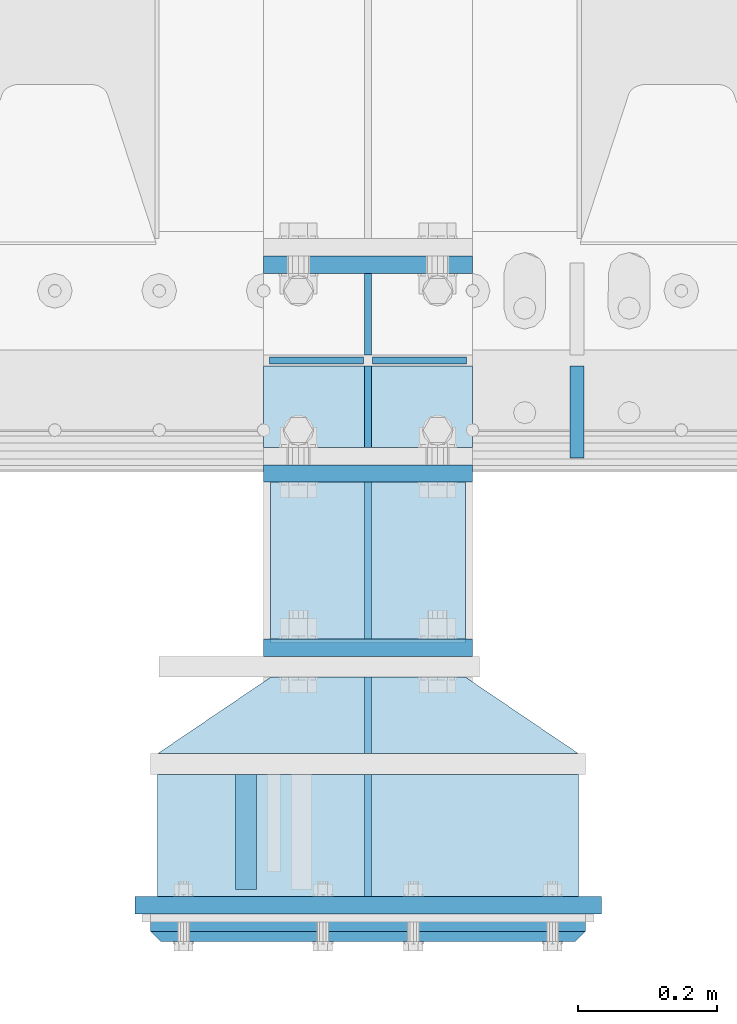
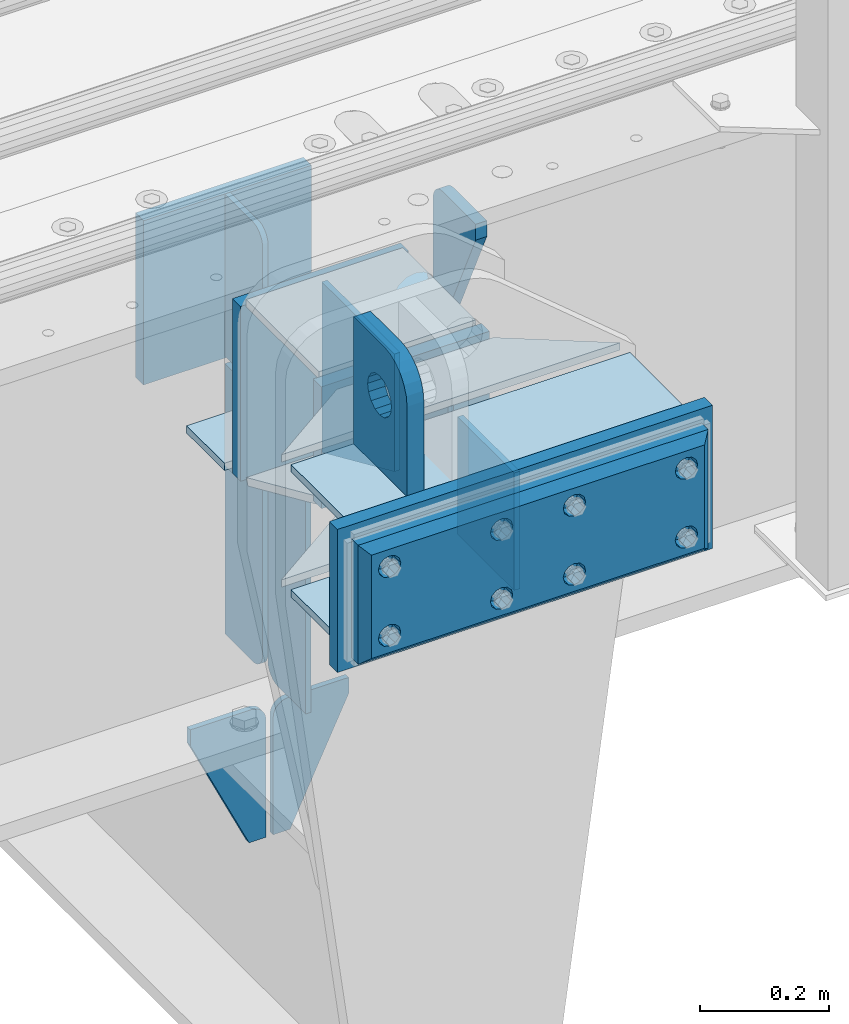
# One storey, part 205 of 247: 22 plates.
"""IFC2X3 building model written with IfcOpenShell, lengths in millimetres."""

from ifc_helpers import new_model, si_unit, frame, origin_with_axes, place, context, subcontext, project, spatial, faceted_brep, material, type_object, element, save


model = new_model("IFC2X3")

# Units and contexts
model_context = context("Model", 3, precision=1e-05, world=origin_with_axes())
body_context = subcontext(model_context, "Body", "Model", "MODEL_VIEW")
ifc_project = project(units=[si_unit("LENGTHUNIT", "METRE", prefix="MILLI"), si_unit("AREAUNIT", "SQUARE_METRE"), si_unit("VOLUMEUNIT", "CUBIC_METRE"), si_unit("MASSUNIT", "GRAM", prefix="KILO"), si_unit("TIMEUNIT", "SECOND"), si_unit("PLANEANGLEUNIT", "RADIAN"), si_unit("SOLIDANGLEUNIT", "STERADIAN"), si_unit("THERMODYNAMICTEMPERATUREUNIT", "DEGREE_CELSIUS"), si_unit("LUMINOUSINTENSITYUNIT", "LUMEN")], contexts=[model_context])

# Site, building, storey
site_placement = place(None, origin_with_axes())
site = spatial("IfcSite", under=ifc_project, at=site_placement, CompositionType="ELEMENT")
building_placement = place(site_placement, origin_with_axes())
building = spatial("IfcBuilding", under=site, at=building_placement, Name="Standard", CompositionType="ELEMENT")
storey_placement = place(building_placement, origin_with_axes())
storey = spatial("IfcBuildingStorey", under=building, at=storey_placement, Name="Undefined", CompositionType="ELEMENT", Elevation=0.0)

# Plates
ifc_material_1 = material(Name="STEEL/S355N")
plate_type_1 = type_object("IfcPlateType", PredefinedType="NOTDEFINED")
plate_1_placement = place(storey_placement, frame((12100.0000000129, -162.500000015315, -340.000018222573), z_axis=(0.0, 0.0, 1.0), x_axis=(1.0, 0.0, 0.0)))
element("IfcPlate", 1, at=plate_1_placement, inside=storey, type_object=plate_type_1, material=ifc_material_1, context=body_context, shape_type="Brep", body=[
    faceted_brep([(0.0, -12.5, 0.0), (0.0, -12.5, 330.0), (0.0, 12.5, 330.0), (0.0, 12.5, 0.0), (300.0, -12.5, 330.0), (300.0, 12.5, 330.0), (300.0, -12.5, 0.0), (300.0, 12.5, 0.0)], [[[0, 1, 2, 3]], [[1, 4, 5, 2]], [[4, 6, 7, 5]], [[6, 0, 3, 7]], [[5, 7, 3, 2]], [[6, 4, 1, 0]]]),
])
plate_2_placement = place(storey_placement, frame((12100.0, 137.5, -340.0), z_axis=(0.0, 0.0, 1.0), x_axis=(1.0, 0.0, 0.0)))
element("IfcPlate", 2, at=plate_2_placement, inside=storey, type_object=plate_type_1, material=ifc_material_1, context=body_context, shape_type="Brep", body=[
    faceted_brep([(0.0, -12.5, 0.0), (0.0, -12.5, 310.0), (0.0, 12.5, 310.0), (0.0, 12.5, 0.0), (300.0, -12.5, 310.0), (300.0, 12.5, 310.0), (300.0, -12.5, 0.0), (300.0, 12.5, 0.0)], [[[0, 1, 2, 3]], [[1, 4, 5, 2]], [[4, 6, 7, 5]], [[6, 0, 3, 7]], [[5, 7, 3, 2]], [[6, 4, 1, 0]]]),
])
plate_type_2 = type_object("IfcPlateType", PredefinedType="NOTDEFINED")
plate_3_placement = place(storey_placement, frame((12250.0000000133, -175.000000015362, -336.000018222573), z_axis=(0.0, -0.999999999999548, -9.5100000000016e-07), x_axis=(0.0, 0.0, 1.0)))
element("IfcPlate", 3, at=plate_3_placement, inside=storey, type_object=plate_type_2, material=ifc_material_1, context=body_context, shape_type="Brep", body=[
    faceted_brep([(9.04219632502645e-09, -5.00000000143385, -2.89173840428703e-09), (100.0, -5.0, 225.0), (100.0, 5.0, 225.0), (7.66340235713869e-09, 4.99999999856618, -2.89173840428703e-09), (322.0, -5.0, 225.0), (322.0, 5.0, 225.0), (322.0, -5.0, 0.0), (322.0, 5.0, 0.0)], [[[0, 1, 2, 3]], [[1, 4, 5, 2]], [[4, 6, 7, 5]], [[6, 0, 3, 7]], [[5, 7, 3, 2]], [[6, 4, 1, 0]]]),
])
plate_type_3 = type_object("IfcPlateType", PredefinedType="NOTDEFINED")
plate_4_placement = place(storey_placement, frame((12074.4999999769, -594.999999983517, -1.82219628186431e-05), z_axis=(0.0, -0.999999999999548, -9.5100000000016e-07), x_axis=(0.0, 0.0, 1.0)))
element("IfcPlate", 4, at=plate_4_placement, inside=storey, type_object=plate_type_3, material=ifc_material_1, context=body_context, shape_type="Brep", body=[
    faceted_brep([(113.837049096098, 15.0, 53.837049096097), (113.837049096098, -15.0, 53.837049096097), (125.840713002492, -15.0, 45.8164572970818), (125.840713002492, 15.0, 45.8164572970818), (105.816457297082, 15.0, 65.8407130024916), (105.816457297082, -15.0, 65.8407130024916), (103.0, 15.0, 80.0), (103.0, -15.0, 80.0), (105.816457297082, 15.0, 94.1592869975084), (105.816457297082, -15.0, 94.1592869975084), (113.837049096098, 15.0, 106.162950903903), (113.837049096098, -15.0, 106.162950903903), (125.840713002492, 15.0, 114.183542702918), (125.840713002492, -15.0, 114.183542702918), (140.0, 15.0, 117.0), (140.0, -15.0, 117.0), (154.159286997508, 15.0, 114.183542702918), (154.159286997508, -15.0, 114.183542702918), (166.162950903902, 15.0, 106.162950903903), (166.162950903902, -15.0, 106.162950903903), (174.183542702918, 15.0, 94.1592869975084), (174.183542702918, -15.0, 94.1592869975084), (177.0, 15.0, 80.0), (177.0, -15.0, 80.0), (174.183542702918, 15.0, 65.8407130024916), (174.183542702918, -15.0, 65.8407130024916), (166.162950903902, 15.0, 53.837049096097), (166.162950903902, -15.0, 53.837049096097), (154.159286997508, 15.0, 45.8164572970818), (154.159286997508, -15.0, 45.8164572970818), (140.0, 15.0, 43.0), (140.0, -15.0, 43.0), (240.0, -15.0, 0.0), (240.0, -15.0, 95.0), (237.614807840235, -15.0, 113.117333157177), (230.621778264911, -15.0, 130.0), (219.497474683058, -15.0, 144.497474683058), (205.0, -15.0, 155.621778264911), (188.117333157176, -15.0, 162.614807840235), (170.0, -15.0, 165.0), (0.0, -15.0, 165.0), (0.0, -15.0, 0.0), (0.0, 15.0, 0.0), (240.0, 15.0, 0.0), (240.0, 15.0, 95.0), (237.614807840235, 15.0, 113.117333157177), (230.621778264911, 15.0, 130.0), (219.497474683058, 15.0, 144.497474683058), (205.0, 15.0, 155.621778264911), (188.117333157176, 15.0, 162.614807840235), (170.0, 15.0, 165.0), (0.0, 15.0, 165.0)], [[[0, 1, 2, 3]], [[4, 5, 1, 0]], [[6, 7, 5, 4]], [[8, 9, 7, 6]], [[10, 11, 9, 8]], [[12, 13, 11, 10]], [[14, 15, 13, 12]], [[16, 17, 15, 14]], [[18, 19, 17, 16]], [[20, 21, 19, 18]], [[22, 23, 21, 20]], [[24, 25, 23, 22]], [[26, 27, 25, 24]], [[28, 29, 27, 26]], [[30, 31, 29, 28]], [[3, 2, 31, 30]], [[32, 33, 34, 35, 36, 37, 38, 39, 40, 41], [19, 21, 23, 25, 27, 29, 31, 2, 1, 5, 7, 9, 11, 13, 15, 17]], [[32, 41, 42, 43]], [[33, 32, 43, 44]], [[34, 33, 44, 45]], [[35, 34, 45, 46]], [[36, 35, 46, 47]], [[37, 36, 47, 48]], [[38, 37, 48, 49]], [[39, 38, 49, 50]], [[40, 39, 50, 51]], [[41, 40, 51, 42]], [[50, 49, 48, 47, 46, 45, 44, 43, 42, 51], [10, 8, 6, 4, 0, 3, 30, 28, 26, 24, 22, 20, 18, 16, 14, 12]]]),
])
plate_type_4 = type_object("IfcPlateType", PredefinedType="NOTDEFINED")
plate_5_placement = place(storey_placement, frame((12100.0, -8.0, -343.0), z_axis=(0.0, -0.999999999999548, -9.5100000000016e-07), x_axis=(1.0, 0.0, 0.0)))
element("IfcPlate", 5, at=plate_5_placement, inside=storey, type_object=plate_type_4, material=ifc_material_1, context=body_context, shape_type="Brep", body=[
    faceted_brep([(0.0, -7.0, 0.0), (0.0, -7.0, 117.0), (0.0, 7.0, 117.0), (0.0, 7.0, 0.0), (300.0, -7.0, 117.0), (300.0, 7.0, 117.0), (300.0, -7.0, 0.0), (300.0, 7.0, 0.0)], [[[0, 1, 2, 3]], [[1, 4, 5, 2]], [[4, 6, 7, 5]], [[6, 0, 3, 7]], [[5, 7, 3, 2]], [[6, 4, 1, 0]]]),
])
plate_type_5 = type_object("IfcPlateType", PredefinedType="NOTDEFINED")
for number, where, z_axis, x_axis in (
    (6, (12250.0, -8.0, -350.0), (0.0, 0.0, -1.0), (0.0, -0.999999999999548, -9.5100000000016e-07)),
    (7, (12250.0, 8.0, -350.0), (0.0, 0.0, -1.0), (0.0, 1.0, 0.0)),
):
    element("IfcPlate", number, at=place(storey_placement, frame(where, z_axis=z_axis, x_axis=x_axis)), inside=storey, type_object=plate_type_5, material=ifc_material_1, context=body_context, shape_type="Brep", body=[
        faceted_brep([(9.04219632502645e-09, -5.00000000143385, -2.89173840428703e-09), (0.0, -5.0, 480.0), (0.0, 5.0, 480.0), (7.66340235713869e-09, 4.99999999856618, -2.89173840428703e-09), (0.455767409633609, -5.0, 485.209445330008), (0.455767409633609, 5.0, 485.209445330008), (1.80922137642256, -5.0, 490.26060429977), (1.80922137642256, 5.0, 490.26060429977), (4.01923788646673, -5.0, 495.0), (4.01923788646673, 5.0, 495.0), (7.01866670643085, -5.0, 499.283628290596), (7.01866670643085, 5.0, 499.283628290596), (10.716371709404, -5.0, 502.981333293569), (10.716371709404, 5.0, 502.981333293569), (15.0, -5.0, 505.980762113533), (15.0, 5.0, 505.980762113533), (19.73939570023, -5.0, 508.190778623577), (19.73939570023, 5.0, 508.190778623577), (24.7905546699922, -5.0, 509.544232590366), (24.7905546699922, 5.0, 509.544232590366), (30.0, -5.0, 510.0), (30.0, 5.0, 510.0), (117.0, -5.0, 510.0), (117.0, 5.0, 510.0), (117.0, -5.0, 0.0), (117.0, 5.0, 0.0)], [[[0, 1, 2, 3]], [[1, 4, 5, 2]], [[4, 6, 7, 5]], [[6, 8, 9, 7]], [[8, 10, 11, 9]], [[10, 12, 13, 11]], [[12, 14, 15, 13]], [[14, 16, 17, 15]], [[16, 18, 19, 17]], [[18, 20, 21, 19]], [[20, 22, 23, 21]], [[22, 24, 25, 23]], [[24, 0, 3, 25]], [[5, 7, 9, 11, 13, 15, 17, 19, 21, 23, 25, 3, 2]], [[24, 22, 20, 18, 16, 14, 12, 10, 8, 6, 4, 1, 0]]]),
    ])
plate_6_placement = place(storey_placement, frame((12250.0, 8.0, -30.0), z_axis=(0.0, 0.0, -1.0), x_axis=(0.0, 1.0, 0.0)))
element("IfcPlate", 8, at=plate_6_placement, inside=storey, type_object=plate_type_5, material=ifc_material_1, context=body_context, shape_type="Brep", body=[
    faceted_brep([(0.0, -5.0, 30.0), (0.0, -5.0, 306.0), (0.0, 5.0, 306.0), (0.0, 5.0, 30.0), (117.0, -5.0, 306.0), (117.0, 5.0, 306.0), (117.0, -5.0, 0.0), (117.0, 5.0, 0.0), (30.0, -5.0, 0.0), (30.0, 5.0, 0.0), (24.7905546699922, -5.0, 0.455767409633758), (24.7905546699922, 5.0, 0.455767409633758), (19.73939570023, -5.0, 1.80922137642275), (19.73939570023, 5.0, 1.80922137642275), (15.0, -5.0, 4.01923788646684), (15.0, 5.0, 4.01923788646684), (10.716371709404, -5.0, 7.01866670643066), (10.716371709404, 5.0, 7.01866670643066), (7.01866670643085, -5.0, 10.7163717094038), (7.01866670643085, 5.0, 10.7163717094038), (4.01923788646673, -5.0, 15.0), (4.01923788646673, 5.0, 15.0), (1.80922137642256, -5.0, 19.7393957002299), (1.80922137642256, 5.0, 19.7393957002299), (0.455767409633609, -5.0, 24.7905546699921), (0.455767409633609, 5.0, 24.7905546699921)], [[[0, 1, 2, 3]], [[1, 4, 5, 2]], [[4, 6, 7, 5]], [[6, 8, 9, 7]], [[8, 10, 11, 9]], [[10, 12, 13, 11]], [[12, 14, 15, 13]], [[14, 16, 17, 15]], [[16, 18, 19, 17]], [[18, 20, 21, 19]], [[20, 22, 23, 21]], [[22, 24, 25, 23]], [[24, 0, 3, 25]], [[5, 7, 9, 11, 13, 15, 17, 19, 21, 23, 25, 3, 2]], [[24, 22, 20, 18, 16, 14, 12, 10, 8, 6, 4, 1, 0]]]),
])
plate_type_6 = type_object("IfcPlateType", PredefinedType="NOTDEFINED")
for number, where, z_axis, x_axis in (
    (9, (12243.5000000132, -1.53546579895192e-08, -915.000018222571), (0.0, 0.0, -1.0), (-1.0, 0.0, 0.0)),
    (10, (12256.5000000133, -1.53597738972167e-08, -915.000018222571), (0.0, 0.0, -1.0), (1.0, 0.0, 0.0)),
):
    element("IfcPlate", number, at=place(storey_placement, frame(where, z_axis=z_axis, x_axis=x_axis)), inside=storey, type_object=plate_type_6, material=ifc_material_1, context=body_context, shape_type="Brep", body=[
        faceted_brep([(0.0, -5.0, 27.0), (0.0, -5.0, 250.0), (0.0, 5.0, 250.0), (0.0, 5.0, 27.0), (30.0, -5.0, 250.0), (30.0, 5.0, 250.0), (135.0, -5.0, 30.0), (135.0, 5.0, 30.0), (135.0, -5.0, 0.0), (135.0, 5.0, 0.0), (27.0, -5.0, 0.0), (27.0, 5.0, 0.0), (22.3114992029932, -5.0, 0.410190668670339), (22.3114992029932, 5.0, 0.410190668670339), (17.7654561302061, -5.0, 1.62829923878041), (17.7654561302061, 5.0, 1.62829923878041), (13.5, -5.0, 3.61731409782021), (13.5, 5.0, 3.61731409782021), (9.64473453846404, -5.0, 6.31680003578765), (9.64473453846404, 5.0, 6.31680003578765), (6.31680003578731, -5.0, 9.64473453846347), (6.31680003578731, 5.0, 9.64473453846347), (3.61731409782078, -5.0, 13.5), (3.61731409782078, 5.0, 13.5), (1.62829923878053, -5.0, 17.765456130207), (1.62829923878053, 5.0, 17.765456130207), (0.410190668670111, -5.0, 22.3114992029929), (0.410190668670111, 5.0, 22.3114992029929)], [[[0, 1, 2, 3]], [[1, 4, 5, 2]], [[4, 6, 7, 5]], [[6, 8, 9, 7]], [[8, 10, 11, 9]], [[10, 12, 13, 11]], [[12, 14, 15, 13]], [[14, 16, 17, 15]], [[16, 18, 19, 17]], [[18, 20, 21, 19]], [[20, 22, 23, 21]], [[22, 24, 25, 23]], [[24, 26, 27, 25]], [[26, 0, 3, 27]], [[5, 7, 9, 11, 13, 15, 17, 19, 21, 23, 25, 27, 3, 2]], [[26, 24, 22, 20, 18, 16, 14, 12, 10, 8, 6, 4, 1, 0]]]),
    ])
plate_type_7 = type_object("IfcPlateType", PredefinedType="NOTDEFINED")
plate_7_placement = place(storey_placement, frame((12550.0, -140.0, -30.0), z_axis=(0.0, 0.0, -1.0), x_axis=(0.0, 1.0, 0.0)))
element("IfcPlate", 11, at=plate_7_placement, inside=storey, type_object=plate_type_7, material=ifc_material_1, context=body_context, shape_type="Brep", body=[
    faceted_brep([(-5.6843418860808e-14, -9.99999999999989, 3.5527136788005e-15), (0.0, -10.0, 30.0), (0.0, 10.0, 30.0), (-5.6843418860808e-14, 10.0000000000001, 3.5527136788005e-15), (102.0, -10.0, 250.0), (102.0, 10.0, 250.0), (132.0, -10.0, 250.0), (132.0, 10.0, 250.0), (132.0, -10.0, 30.0), (132.0, 10.0, 30.0), (131.544232590366, -10.0, 24.790554669992), (131.544232590366, 10.0, 24.790554669992), (130.190778623577, -10.0, 19.7393957002299), (130.190778623577, 10.0, 19.7393957002299), (127.980762113533, -10.0, 15.0), (127.980762113533, 10.0, 15.0), (124.981333293569, -10.0, 10.7163717094038), (124.981333293569, 10.0, 10.7163717094038), (121.283628290596, -10.0, 7.01866670643062), (121.283628290596, 10.0, 7.01866670643062), (117.0, -10.0, 4.01923788646684), (117.0, 10.0, 4.01923788646684), (112.26060429977, -10.0, 1.80922137642278), (112.26060429977, 10.0, 1.80922137642278), (107.209445330008, -10.0, 0.455767409633722), (107.209445330008, 10.0, 0.455767409633722), (102.0, -10.0, 0.0), (102.0, 10.0, 0.0)], [[[0, 1, 2, 3]], [[1, 4, 5, 2]], [[4, 6, 7, 5]], [[6, 8, 9, 7]], [[8, 10, 11, 9]], [[10, 12, 13, 11]], [[12, 14, 15, 13]], [[14, 16, 17, 15]], [[16, 18, 19, 17]], [[18, 20, 21, 19]], [[20, 22, 23, 21]], [[22, 24, 25, 23]], [[24, 26, 27, 25]], [[26, 0, 3, 27]], [[5, 7, 9, 11, 13, 15, 17, 19, 21, 23, 25, 27, 3, 2]], [[26, 24, 22, 20, 18, 16, 14, 12, 10, 8, 6, 4, 1, 0]]]),
])
plate_type_8 = type_object("IfcPlateType", PredefinedType="NOTDEFINED")
plate_8_placement = place(storey_placement, frame((12250.0000000135, -770.000000015376, -14.0000182225729), z_axis=(0.0, 0.0, -1.0), x_axis=(0.0, 1.0, 0.0)))
element("IfcPlate", 12, at=plate_8_placement, inside=storey, type_object=plate_type_8, material=ifc_material_1, context=body_context, shape_type="Brep", body=[
    faceted_brep([(9.04219632502645e-09, -5.00000000143385, -2.89173840428703e-09), (0.0, -5.0, 222.0), (0.0, 5.0, 222.0), (7.66340235713869e-09, 4.99999999856618, -2.89173840428703e-09), (175.0, -5.0, 222.0), (175.0, 5.0, 222.0), (175.0, -5.0, 0.0), (175.0, 5.0, 0.0)], [[[0, 1, 2, 3]], [[1, 4, 5, 2]], [[4, 6, 7, 5]], [[6, 0, 3, 7]], [[5, 7, 3, 2]], [[6, 4, 1, 0]]]),
])
plate_type_9 = type_object("IfcPlateType", PredefinedType="NOTDEFINED")
plate_9_placement = place(storey_placement, frame((12250.0000000134, -565.00000001537, -14.0000182225729), z_axis=(0.0, 0.0, -1.0), x_axis=(0.0, 1.0, 0.0)))
element("IfcPlate", 13, at=plate_9_placement, inside=storey, type_object=plate_type_9, material=ifc_material_1, context=body_context, shape_type="Brep", body=[
    faceted_brep([(9.04219632502645e-09, -5.00000000143385, -2.89173840428703e-09), (0.0, -5.0, 222.0), (0.0, 5.0, 222.0), (7.66340235713869e-09, 4.99999999856618, -2.89173840428703e-09), (110.0, -5.0, 222.0), (110.0, 5.0, 222.0), (110.0, -5.0, 0.0), (110.0, 5.0, 0.0)], [[[0, 1, 2, 3]], [[1, 4, 5, 2]], [[4, 6, 7, 5]], [[6, 0, 3, 7]], [[5, 7, 3, 2]], [[6, 4, 1, 0]]]),
])
ifc_material_2 = material()
plate_type_10 = type_object("IfcPlateType", PredefinedType="NOTDEFINED")
for number, where, z_axis, x_axis in (
    (14, (12552.5000000142, -595.000000015467, -7.00001822257286), (0.0, -0.999999999999548, -9.5100000000016e-07), (-1.0, 0.0, 0.0)),
    (15, (12552.5000000142, -595.000000015467, -243.000018222573), (0.0, -0.999999999999548, -9.5100000000016e-07), (-1.0, 0.0, 0.0)),
):
    element("IfcPlate", number, at=place(storey_placement, frame(where, z_axis=z_axis, x_axis=x_axis)), inside=storey, type_object=plate_type_10, material=ifc_material_2, context=body_context, shape_type="Brep", body=[
        faceted_brep([(0.0, -7.0, 0.0), (0.0, -7.0, 175.0), (0.0, 7.0, 175.0), (0.0, 7.0, 0.0), (605.0, -7.0, 175.0), (605.0, 7.0, 175.0), (605.0, -7.0, 0.0), (605.0, 7.0, 0.0)], [[[0, 1, 2, 3]], [[1, 4, 5, 2]], [[4, 6, 7, 5]], [[6, 0, 3, 7]], [[5, 7, 3, 2]], [[6, 4, 1, 0]]]),
    ])
plate_type_11 = type_object("IfcPlateType", PredefinedType="NOTDEFINED")
for number, where, z_axis, x_axis in (
    (16, (12552.5000000142, -565.000000015465, -243.000018222573), (-0.560566412034006, -0.828109472050236, 0.0), (-0.828109472050236, 0.560566412034006, 0.0)),
    (17, (12552.5000000142, -565.000000015465, -7.00001822257286), (-0.560566412034006, -0.828109472050236, 0.0), (-0.828109472050236, 0.560566412034006, 0.0)),
):
    element("IfcPlate", number, at=place(storey_placement, frame(where, z_axis=z_axis, x_axis=x_axis)), inside=storey, type_object=plate_type_11, material=ifc_material_1, context=body_context, shape_type="Brep", body=[
        faceted_brep([(0.0, -7.0, 0.0), (501.006225585938, -7.0, 339.142669677734), (501.006225585938, 7.0, 339.142669677734), (0.0, 7.0, 0.0), (428.100738525391, -7.0, 156.958602905274), (428.100738525391, 7.0, 156.958602905274), (196.230087280275, -7.0, -3.64934749086387e-11), (196.230087280275, 7.0, -3.64934749086387e-11)], [[[0, 1, 2, 3]], [[1, 4, 5, 2]], [[4, 6, 7, 5]], [[6, 0, 3, 7]], [[5, 7, 3, 2]], [[6, 4, 1, 0]]]),
    ])
plate_type_12 = type_object("IfcPlateType", PredefinedType="NOTDEFINED")
plate_10_placement = place(storey_placement, frame((12585.0000000144, -782.500000015481, 9.99998177742714), z_axis=(0.0, 0.0, -1.0), x_axis=(-1.0, 0.0, 0.0)))
element("IfcPlate", 18, at=plate_10_placement, inside=storey, type_object=plate_type_12, material=ifc_material_1, context=body_context, shape_type="Brep", body=[
    faceted_brep([(0.0, -12.5, 0.0), (0.0, -12.5, 270.0), (0.0, 12.5, 270.0), (0.0, 12.5, 0.0), (670.0, -12.5, 270.0), (670.0, 12.5, 270.0), (670.0, -12.5, 0.0), (670.0, 12.5, 0.0)], [[[0, 1, 2, 3]], [[1, 4, 5, 2]], [[4, 6, 7, 5]], [[6, 0, 3, 7]], [[5, 7, 3, 2]], [[6, 4, 1, 0]]]),
])
plate_type_13 = type_object("IfcPlateType", PredefinedType="NOTDEFINED")
plate_11_placement = place(storey_placement, frame((12100.000000013, -412.50000001532, -240.000018222573), z_axis=(0.0, 0.0, 1.0), x_axis=(1.0, 0.0, 0.0)))
element("IfcPlate", 19, at=plate_11_placement, inside=storey, type_object=plate_type_13, material=ifc_material_1, context=body_context, shape_type="Brep", body=[
    faceted_brep([(0.0, -12.5, 0.0), (0.0, -12.5, 230.0), (0.0, 12.5, 230.0), (0.0, 12.5, 0.0), (300.0, -12.5, 230.0), (300.0, 12.5, 230.0), (300.0, -12.5, 0.0), (300.0, 12.5, 0.0)], [[[0, 1, 2, 3]], [[1, 4, 5, 2]], [[4, 6, 7, 5]], [[6, 0, 3, 7]], [[5, 7, 3, 2]], [[6, 4, 1, 0]]]),
])
ifc_material_3 = material()
plate_type_14 = type_object("IfcPlateType", PredefinedType="NOTDEFINED")
plate_12_placement = place(storey_placement, frame((12562.5000000143, -815.000000015475, -12.5000182225729), z_axis=(0.0, 0.0, -1.0), x_axis=(-1.0, 0.0, 0.0)))
element("IfcPlate", 20, at=plate_12_placement, inside=storey, type_object=plate_type_14, material=ifc_material_3, context=body_context, shape_type="Brep", body=[
    faceted_brep([(9.04219632502645e-09, -5.00000000143385, -2.89173840428703e-09), (15.0, -20.0, 15.0), (15.0, -20.0, 210.0), (0.0, -5.0, 225.0), (625.0, -5.0, 225.0), (610.0, -20.0, 210.0), (610.0, -20.0, 15.0), (625.0, -5.0, 0.0), (625.0, 15.0, 0.0), (620.0, 20.0, 5.0), (620.0, 20.0, 220.0), (625.0, 15.0, 225.0), (0.0, 15.0, 225.0), (5.0, 20.0, 220.0), (5.0, 20.0, 5.0), (0.0, 15.0, 0.0), (30.1794919244185, 5.00000000001501, 37.4999999999982), (37.5000000001073, 5.00000000001501, 30.1794919243094), (47.5000000001073, 5.00000000001501, 27.4999999999982), (57.5000000001073, 5.00000000001501, 30.1794919243094), (64.8205080757962, 5.00000000001501, 37.4999999999982), (67.5000000001073, 5.00000000001501, 47.4999999999982), (64.8205080757962, 5.00000000001501, 57.4999999999982), (57.5000000001073, 5.00000000001501, 64.8205080756869), (47.5000000001073, 5.00000000001501, 67.4999999999982), (37.5000000001073, 5.00000000001501, 64.820508075687), (30.1794919244185, 5.00000000001501, 57.4999999999982), (27.5000000001073, 5.00000000001501, 47.4999999999982), (37.5000000001073, -20.0, 30.1794919243094), (30.1794919244185, -20.0, 37.4999999999982), (47.5000000001073, -20.0, 27.4999999999982), (57.5000000001073, -20.0, 30.1794919243094), (64.8205080757962, -20.0, 37.4999999999982), (67.5000000001073, -20.0, 47.4999999999982), (64.8205080757962, -20.0, 57.4999999999982), (57.5000000001073, -20.0, 64.8205080756869), (47.5000000001073, -20.0, 67.4999999999982), (37.5000000001073, -20.0, 64.820508075687), (30.1794919244185, -20.0, 57.4999999999982), (27.5000000001073, -20.0, 47.4999999999982), (360.179491925306, 5.00000000011846, 37.4999999999982), (367.500000000995, 5.00000000011846, 30.1794919243094), (377.500000000995, 5.00000000011846, 27.4999999999982), (387.500000000995, 5.00000000011846, 30.1794919243094), (394.820508076684, 5.00000000011846, 37.4999999999982), (397.500000000995, 5.00000000011846, 47.4999999999982), (394.820508076684, 5.00000000011846, 57.4999999999982), (387.500000000995, 5.00000000011846, 64.8205080756869), (377.500000000995, 5.00000000011846, 67.4999999999982), (367.500000000995, 5.00000000011846, 64.820508075687), (360.179491925306, 5.00000000011846, 57.4999999999982), (357.500000000995, 5.00000000011846, 47.4999999999982), (360.179491925306, -20.0, 37.4999999999982), (357.500000000995, -20.0, 47.4999999999982), (367.500000000995, -20.0, 30.1794919243094), (377.500000000995, -20.0, 27.4999999999982), (387.500000000995, -20.0, 30.1794919243094), (394.820508076684, -20.0, 37.4999999999982), (397.500000000995, -20.0, 47.4999999999982), (394.820508076684, -20.0, 57.4999999999982), (387.500000000995, -20.0, 64.8205080756869), (377.500000000995, -20.0, 67.4999999999982), (367.500000000995, -20.0, 64.820508075687), (360.179491925306, -20.0, 57.4999999999982), (360.179491925306, 5.00000000011846, 167.499999999998), (367.500000000995, 5.00000000011846, 160.179491924309), (377.500000000995, 5.00000000011846, 157.499999999998), (387.500000000995, 5.00000000011846, 160.179491924309), (394.820508076684, 5.00000000011846, 167.499999999998), (397.500000000995, 5.00000000011846, 177.499999999998), (394.820508076684, 5.00000000011846, 187.499999999998), (387.500000000995, 5.00000000011846, 194.820508075687), (377.500000000995, 5.00000000011846, 197.499999999998), (367.500000000995, 5.00000000011846, 194.820508075687), (360.179491925306, 5.00000000011846, 187.499999999998), (357.500000000995, 5.00000000011846, 177.499999999998), (360.179491925306, -20.0, 167.499999999998), (357.500000000995, -20.0, 177.499999999998), (367.500000000995, -20.0, 160.179491924309), (377.500000000995, -20.0, 157.499999999998), (387.500000000995, -20.0, 160.179491924309), (394.820508076684, -20.0, 167.499999999998), (397.500000000995, -20.0, 177.499999999998), (394.820508076684, -20.0, 187.499999999998), (387.500000000995, -20.0, 194.820508075687), (377.500000000995, -20.0, 197.499999999998), (367.500000000995, -20.0, 194.820508075687), (360.179491925306, -20.0, 187.499999999998), (560.179491925845, 5.0000000001811, 167.499999999998), (567.500000001533, 5.0000000001811, 160.179491924309), (577.500000001533, 5.0000000001811, 157.499999999998), (587.500000001533, 5.0000000001811, 160.179491924309), (594.820508077222, 5.0000000001811, 167.499999999998), (597.500000001533, 5.0000000001811, 177.499999999998), (594.820508077222, 5.0000000001811, 187.499999999998), (587.500000001533, 5.0000000001811, 194.820508075687), (577.500000001533, 5.0000000001811, 197.499999999998), (567.500000001533, 5.0000000001811, 194.820508075687), (560.179491925845, 5.0000000001811, 187.499999999998), (557.500000001533, 5.0000000001811, 177.499999999998), (560.179491925845, -20.0, 167.499999999998), (557.500000001533, -20.0, 177.499999999998), (567.500000001533, -20.0, 160.179491924309), (577.500000001533, -20.0, 157.499999999998), (587.500000001533, -20.0, 160.179491924309), (594.820508077222, -20.0, 167.499999999998), (597.500000001533, -20.0, 177.499999999998), (594.820508077222, -20.0, 187.499999999998), (587.500000001533, -20.0, 194.820508075687), (577.500000001533, -20.0, 197.499999999998), (567.500000001533, -20.0, 194.820508075687), (560.179491925845, -20.0, 187.499999999998), (230.179491924957, 5.00000000007765, 37.4999999999982), (237.500000000646, 5.00000000007765, 30.1794919243094), (247.500000000646, 5.00000000007765, 27.4999999999982), (257.500000000646, 5.00000000007765, 30.1794919243094), (264.820508076335, 5.00000000007765, 37.4999999999982), (267.500000000646, 5.00000000007765, 47.4999999999982), (264.820508076335, 5.00000000007765, 57.4999999999982), (257.500000000646, 5.00000000007765, 64.8205080756869), (247.500000000646, 5.00000000007765, 67.4999999999982), (237.500000000646, 5.00000000007765, 64.820508075687), (230.179491924957, 5.00000000007765, 57.4999999999982), (227.500000000646, 5.00000000007765, 47.4999999999982), (230.179491924957, -20.0, 37.4999999999982), (227.500000000646, -20.0, 47.4999999999982), (237.500000000646, -20.0, 30.1794919243094), (247.500000000646, -20.0, 27.4999999999982), (257.500000000646, -20.0, 30.1794919243094), (264.820508076335, -20.0, 37.4999999999982), (267.500000000646, -20.0, 47.4999999999982), (264.820508076335, -20.0, 57.4999999999982), (257.500000000646, -20.0, 64.8205080756869), (247.500000000646, -20.0, 67.4999999999982), (237.500000000646, -20.0, 64.820508075687), (230.179491924957, -20.0, 57.4999999999982), (30.1794919244185, 5.00000000001501, 167.499999999998), (37.5000000001073, 5.00000000001501, 160.179491924309), (47.5000000001073, 5.00000000001501, 157.499999999998), (57.5000000001073, 5.00000000001501, 160.179491924309), (64.8205080757962, 5.00000000001501, 167.499999999998), (67.5000000001073, 5.00000000001501, 177.499999999998), (64.8205080757962, 5.00000000001501, 187.499999999998), (57.5000000001073, 5.00000000001501, 194.820508075687), (47.5000000001073, 5.00000000001501, 197.499999999998), (37.5000000001073, 5.00000000001501, 194.820508075687), (30.1794919244185, 5.00000000001501, 187.499999999998), (27.5000000001073, 5.00000000001501, 177.499999999998), (30.1794919244185, -20.0, 167.499999999998), (27.5000000001073, -20.0, 177.499999999998), (37.5000000001073, -20.0, 160.179491924309), (47.5000000001073, -20.0, 157.499999999998), (57.5000000001073, -20.0, 160.179491924309), (64.8205080757962, -20.0, 167.499999999998), (67.5000000001073, -20.0, 177.499999999998), (64.8205080757962, -20.0, 187.499999999998), (57.5000000001073, -20.0, 194.820508075687), (47.5000000001073, -20.0, 197.499999999998), (37.5000000001073, -20.0, 194.820508075687), (30.1794919244185, -20.0, 187.499999999998), (230.179491924957, 5.00000000007765, 167.499999999998), (237.500000000646, 5.00000000007765, 160.179491924309), (247.500000000646, 5.00000000007765, 157.499999999998), (257.500000000646, 5.00000000007765, 160.179491924309), (264.820508076335, 5.00000000007765, 167.499999999998), (267.500000000646, 5.00000000007765, 177.499999999998), (264.820508076335, 5.00000000007765, 187.499999999998), (257.500000000646, 5.00000000007765, 194.820508075687), (247.500000000646, 5.00000000007765, 197.499999999998), (237.500000000646, 5.00000000007765, 194.820508075687), (230.179491924957, 5.00000000007765, 187.499999999998), (227.500000000646, 5.00000000007765, 177.499999999998), (230.179491924957, -20.0, 167.499999999998), (227.500000000646, -20.0, 177.499999999998), (237.500000000646, -20.0, 160.179491924309), (247.500000000646, -20.0, 157.499999999998), (257.500000000646, -20.0, 160.179491924309), (264.820508076335, -20.0, 167.499999999998), (267.500000000646, -20.0, 177.499999999998), (264.820508076335, -20.0, 187.499999999998), (257.500000000646, -20.0, 194.820508075687), (247.500000000646, -20.0, 197.499999999998), (237.500000000646, -20.0, 194.820508075687), (230.179491924957, -20.0, 187.499999999998), (560.179491925845, 5.0000000001811, 37.4999999999982), (567.500000001533, 5.0000000001811, 30.1794919243094), (577.500000001533, 5.0000000001811, 27.4999999999982), (587.500000001533, 5.0000000001811, 30.1794919243094), (594.820508077222, 5.0000000001811, 37.4999999999982), (597.500000001533, 5.0000000001811, 47.4999999999982), (594.820508077222, 5.0000000001811, 57.4999999999982), (587.500000001533, 5.0000000001811, 64.8205080756869), (577.500000001533, 5.0000000001811, 67.4999999999982), (567.500000001533, 5.0000000001811, 64.820508075687), (560.179491925845, 5.0000000001811, 57.4999999999982), (557.500000001533, 5.0000000001811, 47.4999999999982), (560.179491925845, -20.0, 37.4999999999982), (557.500000001533, -20.0, 47.4999999999982), (567.500000001533, -20.0, 30.1794919243094), (577.500000001533, -20.0, 27.4999999999982), (587.500000001533, -20.0, 30.1794919243094), (594.820508077222, -20.0, 37.4999999999982), (597.500000001533, -20.0, 47.4999999999982), (594.820508077222, -20.0, 57.4999999999982), (587.500000001533, -20.0, 64.8205080756869), (577.500000001533, -20.0, 67.4999999999982), (567.500000001533, -20.0, 64.820508075687), (560.179491925845, -20.0, 57.4999999999982)], [[[0, 1, 2, 3]], [[4, 5, 6, 7]], [[8, 9, 10, 11]], [[12, 13, 14, 15]], [[15, 14, 9, 8]], [[5, 4, 3, 2]], [[13, 12, 11, 10]], [[7, 6, 1, 0]], [[16, 17, 18, 19, 20, 21, 22, 23, 24, 25, 26, 27]], [[28, 17, 16, 29]], [[30, 18, 17, 28]], [[31, 19, 18, 30]], [[32, 20, 19, 31]], [[33, 21, 20, 32]], [[34, 22, 21, 33]], [[35, 23, 22, 34]], [[36, 24, 23, 35]], [[37, 25, 24, 36]], [[38, 26, 25, 37]], [[39, 27, 26, 38]], [[29, 16, 27, 39]], [[11, 12, 3, 4]], [[8, 11, 4, 7]], [[7, 0, 15, 8]], [[14, 13, 10, 9]], [[12, 15, 0, 3]], [[40, 41, 42, 43, 44, 45, 46, 47, 48, 49, 50, 51]], [[52, 40, 51, 53]], [[54, 41, 40, 52]], [[55, 42, 41, 54]], [[56, 43, 42, 55]], [[57, 44, 43, 56]], [[58, 45, 44, 57]], [[59, 46, 45, 58]], [[60, 47, 46, 59]], [[61, 48, 47, 60]], [[62, 49, 48, 61]], [[63, 50, 49, 62]], [[53, 51, 50, 63]], [[64, 65, 66, 67, 68, 69, 70, 71, 72, 73, 74, 75]], [[76, 64, 75, 77]], [[78, 65, 64, 76]], [[79, 66, 65, 78]], [[80, 67, 66, 79]], [[81, 68, 67, 80]], [[82, 69, 68, 81]], [[83, 70, 69, 82]], [[84, 71, 70, 83]], [[85, 72, 71, 84]], [[86, 73, 72, 85]], [[87, 74, 73, 86]], [[77, 75, 74, 87]], [[88, 89, 90, 91, 92, 93, 94, 95, 96, 97, 98, 99]], [[100, 88, 99, 101]], [[102, 89, 88, 100]], [[103, 90, 89, 102]], [[104, 91, 90, 103]], [[105, 92, 91, 104]], [[106, 93, 92, 105]], [[107, 94, 93, 106]], [[108, 95, 94, 107]], [[109, 96, 95, 108]], [[110, 97, 96, 109]], [[111, 98, 97, 110]], [[101, 99, 98, 111]], [[112, 113, 114, 115, 116, 117, 118, 119, 120, 121, 122, 123]], [[124, 112, 123, 125]], [[126, 113, 112, 124]], [[127, 114, 113, 126]], [[128, 115, 114, 127]], [[129, 116, 115, 128]], [[130, 117, 116, 129]], [[131, 118, 117, 130]], [[132, 119, 118, 131]], [[133, 120, 119, 132]], [[134, 121, 120, 133]], [[135, 122, 121, 134]], [[125, 123, 122, 135]], [[136, 137, 138, 139, 140, 141, 142, 143, 144, 145, 146, 147]], [[148, 136, 147, 149]], [[150, 137, 136, 148]], [[151, 138, 137, 150]], [[152, 139, 138, 151]], [[153, 140, 139, 152]], [[154, 141, 140, 153]], [[155, 142, 141, 154]], [[156, 143, 142, 155]], [[157, 144, 143, 156]], [[158, 145, 144, 157]], [[159, 146, 145, 158]], [[149, 147, 146, 159]], [[160, 161, 162, 163, 164, 165, 166, 167, 168, 169, 170, 171]], [[172, 160, 171, 173]], [[174, 161, 160, 172]], [[175, 162, 161, 174]], [[176, 163, 162, 175]], [[177, 164, 163, 176]], [[178, 165, 164, 177]], [[179, 166, 165, 178]], [[180, 167, 166, 179]], [[181, 168, 167, 180]], [[182, 169, 168, 181]], [[183, 170, 169, 182]], [[173, 171, 170, 183]], [[184, 185, 186, 187, 188, 189, 190, 191, 192, 193, 194, 195]], [[196, 184, 195, 197]], [[198, 185, 184, 196]], [[199, 186, 185, 198]], [[200, 187, 186, 199]], [[201, 188, 187, 200]], [[202, 189, 188, 201]], [[203, 190, 189, 202]], [[204, 191, 190, 203]], [[205, 192, 191, 204]], [[206, 193, 192, 205]], [[207, 194, 193, 206]], [[197, 195, 194, 207]], [[6, 5, 2, 1], [37, 36, 35, 34, 33, 32, 31, 30, 28, 29, 39, 38], [206, 205, 204, 203, 202, 201, 200, 199, 198, 196, 197, 207], [182, 181, 180, 179, 178, 177, 176, 175, 174, 172, 173, 183], [158, 157, 156, 155, 154, 153, 152, 151, 150, 148, 149, 159], [134, 133, 132, 131, 130, 129, 128, 127, 126, 124, 125, 135], [110, 109, 108, 107, 106, 105, 104, 103, 102, 100, 101, 111], [86, 85, 84, 83, 82, 81, 80, 79, 78, 76, 77, 87], [62, 61, 60, 59, 58, 57, 56, 55, 54, 52, 53, 63]]]),
])
plate_type_15 = type_object("IfcPlateType", PredefinedType="NOTDEFINED")
plate_13_placement = place(storey_placement, frame((12110.0000000129, -175.000000015319, -7.00001822257286), z_axis=(0.0, -0.999999999999548, -9.5100000000016e-07), x_axis=(1.0, 0.0, 0.0)))
element("IfcPlate", 21, at=plate_13_placement, inside=storey, type_object=plate_type_15, material=ifc_material_1, context=body_context, shape_type="Brep", body=[
    faceted_brep([(0.0, -7.0, 0.0), (0.0, -7.0, 225.0), (0.0, 7.0, 225.0), (0.0, 7.0, 0.0), (280.0, -7.0, 225.0), (280.0, 7.0, 225.0), (280.0, -7.0, 0.0), (280.0, 7.0, 0.0)], [[[0, 1, 2, 3]], [[1, 4, 5, 2]], [[4, 6, 7, 5]], [[6, 0, 3, 7]], [[5, 7, 3, 2]], [[6, 4, 1, 0]]]),
])
plate_type_16 = type_object("IfcPlateType", PredefinedType="NOTDEFINED")
plate_14_placement = place(storey_placement, frame((12110.0000000129, -177.842969276394, -342.396699063492), z_axis=(0.0, -0.913811548702731, 0.406138465867881), x_axis=(1.0, 0.0, 0.0)))
element("IfcPlate", 22, at=plate_14_placement, inside=storey, type_object=plate_type_16, material=ifc_material_1, context=body_context, shape_type="Brep", body=[
    faceted_brep([(0.0, -7.0, 0.0), (0.0, -7.0, 246.221450805664), (0.0, 7.0, 246.221450805666), (0.0, 7.0, 0.0), (280.0, -7.0, 246.221450805664), (280.0, 7.0, 246.221450805666), (280.0, -7.0, 0.0), (280.0, 7.0, 0.0)], [[[0, 1, 2, 3]], [[1, 4, 5, 2]], [[4, 6, 7, 5]], [[6, 0, 3, 7]], [[5, 7, 3, 2]], [[6, 4, 1, 0]]]),
])

save(model, "model.ifc")
